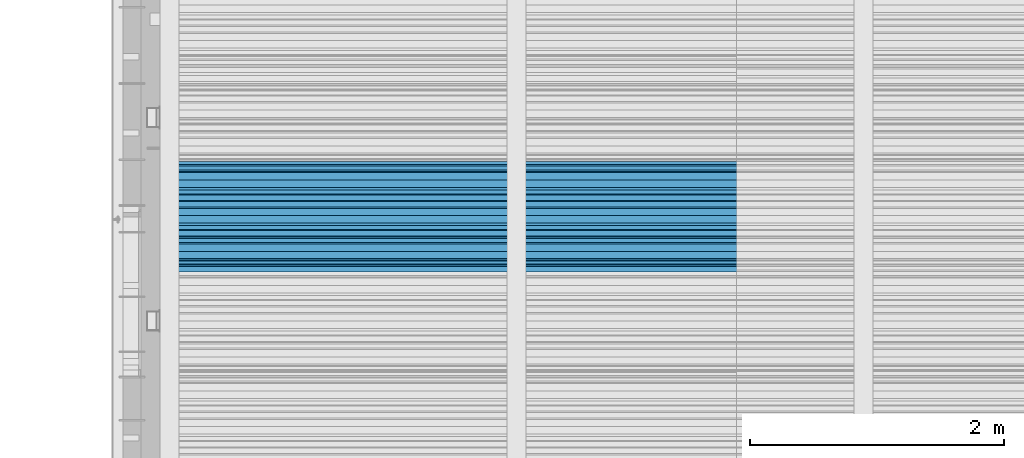
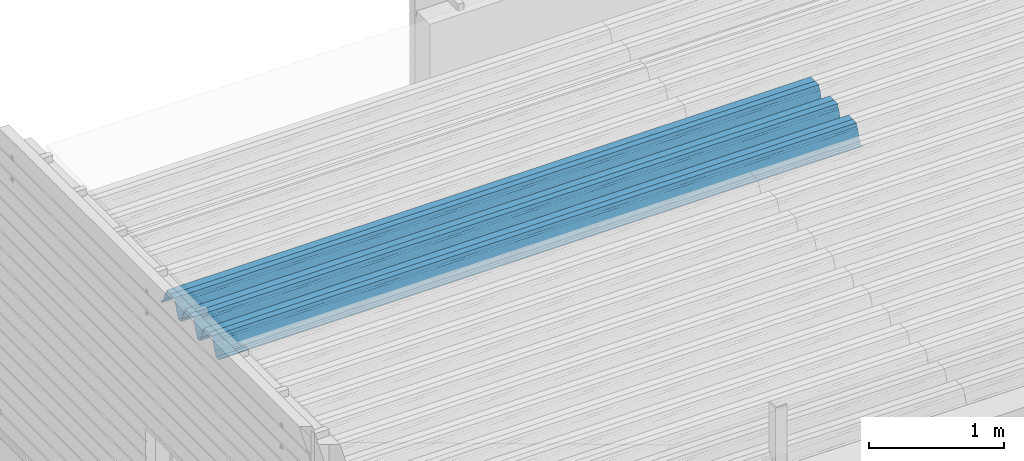
# One storey, part 28 of 153: 1 beam, 1 element without a shape of its own.
"""IFC2X3 building model written with IfcOpenShell, lengths in millimetres."""

from ifc_helpers import new_model, si_unit, frame, origin_with_axes, place, context, subcontext, project, spatial, faceted_brep, material, type_object, element, aggregate, save


model = new_model("IFC2X3")

# Units and contexts
model_context = context("Model", 3, precision=1e-05, world=origin_with_axes())
body_context = subcontext(model_context, "Body", "Model", "MODEL_VIEW")
ifc_project = project(units=[si_unit("LENGTHUNIT", "METRE", prefix="MILLI"), si_unit("AREAUNIT", "SQUARE_METRE"), si_unit("VOLUMEUNIT", "CUBIC_METRE"), si_unit("MASSUNIT", "GRAM", prefix="KILO"), si_unit("TIMEUNIT", "SECOND"), si_unit("PLANEANGLEUNIT", "RADIAN"), si_unit("SOLIDANGLEUNIT", "STERADIAN"), si_unit("THERMODYNAMICTEMPERATUREUNIT", "DEGREE_CELSIUS"), si_unit("LUMINOUSINTENSITYUNIT", "LUMEN")], contexts=[model_context])

# Site, building, storey
site_placement = place(None, origin_with_axes())
site = spatial("IfcSite", under=ifc_project, at=site_placement, CompositionType="ELEMENT")
building_placement = place(site_placement, origin_with_axes())
building = spatial("IfcBuilding", under=site, at=building_placement, CompositionType="ELEMENT")
storey_placement = place(building_placement, origin_with_axes())
storey = spatial("IfcBuildingStorey", under=building, at=storey_placement, Name="8", CompositionType="ELEMENT", Elevation=0.0)

# Assembly, beam
assembly_placement = place(storey_placement, origin_with_axes())
assembly = element("IfcElementAssembly", 1, at=assembly_placement, inside=storey, Name="Steel Assembly", AssemblyPlace="NOTDEFINED", PredefinedType="RIGID_FRAME")
ifc_material = material(Name="STEEL/S355J2")
beam_type = type_object("IfcBeamType", Name="W", PredefinedType="NOTDEFINED")
beam_placement = place(assembly_placement, frame((13534.9999999929, 18704.9497094765, 105791.397257998), z_axis=(0.0, -0.0124990270013869, 0.999921884110963), x_axis=(-1.0, 3.00000001838171e-08, 0.0)))
beam = element("IfcBeam", 2, at=beam_placement, type_object=beam_type, material=ifc_material, ObjectType="W", context=body_context, shape_type="Brep", body=[
    faceted_brep([(0.0, -412.839996337891, -77.0100021362159), (0.0, -409.160003662109, -77.0100021362014), (5530.0, -409.160003662109, -77.0100021362014), (5530.0, -412.839996337891, -77.0100021362159), (0.0, -408.070007324222, -73.4800033569045), (5530.0, -408.070007324222, -73.4800033569045), (0.0, -400.339996337894, -48.0600013732619), (5530.0, -400.339996337894, -48.0600013732619), (0.0, -399.459991455082, -46.5600013732619), (5530.0, -399.459991455082, -46.5600013732619), (0.0, -390.329986572269, -36.5499992370314), (5530.0, -390.329986572269, -36.5499992370314), (0.0, -389.19000244141, -34.6300010680861), (5530.0, -389.19000244141, -34.6300010680861), (0.0, -367.820007324222, 35.3400001526024), (5530.0, -367.820007324222, 35.3400001526024), (0.0, -366.989990234379, 36.8499984741502), (5530.0, -366.989990234379, 36.8499984741502), (0.0, -357.809997558597, 46.8600006103807), (5530.0, -357.809997558597, 46.8600006103807), (0.0, -356.720001220707, 48.7700004577782), (5530.0, -356.720001220707, 48.7700004577782), (0.0, -349.309997558594, 73.1500015258935), (5530.0, -349.309997558594, 73.1500015258935), (0.0, -347.850006103516, 75.2300033569481), (5530.0, -347.850006103516, 75.2300033569481), (0.0, -345.470001220707, 76.010002136245), (5530.0, -345.470001220707, 76.010002136245), (0.0, -305.480010986332, 76.010002136245), (5530.0, -305.480010986332, 76.010002136245), (0.0, -304.279998779301, 75.8000030517578), (5530.0, -304.279998779301, 75.8000030517578), (0.0, -291.679992675785, 71.6999969482567), (5530.0, -291.679992675785, 71.6999969482567), (0.0, -290.179992675789, 71.2300033569481), (5530.0, -290.179992675789, 71.2300033569481), (0.0, -288.720001220707, 71.6999969482567), (5530.0, -288.720001220707, 71.6999969482567), (0.0, -276.119995117191, 75.8000030517869), (5530.0, -276.119995117191, 75.8000030517869), (0.0, -274.929992675785, 76.010002136245), (5530.0, -274.929992675785, 76.010002136245), (0.0, -234.94000244141, 76.010002136245), (5530.0, -234.94000244141, 76.010002136245), (0.0, -232.550003051758, 75.2300033569627), (5530.0, -232.550003051758, 75.2300033569627), (0.0, -231.100006103519, 73.1500015258935), (5530.0, -231.100006103519, 73.1500015258935), (0.0, -223.679992675785, 48.7700004577782), (5530.0, -223.679992675785, 48.7700004577782), (0.0, -222.589996337894, 46.8600006103661), (5530.0, -222.589996337894, 46.8600006103661), (0.0, -213.410003662113, 36.8499984741502), (5530.0, -213.410003662113, 36.8499984741502), (0.0, -212.529998779301, 35.3400001526024), (5530.0, -212.529998779301, 35.3400001526024), (0.0, -191.160003662109, -34.6300010681007), (5530.0, -191.160003662109, -34.6300010681007), (0.0, -190.070007324222, -36.5499992370605), (5530.0, -190.070007324222, -36.5499992370605), (0.0, -180.940002441406, -46.560001373291), (5530.0, -180.940002441406, -46.560001373291), (0.0, -180.059997558597, -48.0600013732619), (5530.0, -180.059997558597, -48.0600013732619), (0.0, -172.330001831055, -73.480003356919), (5530.0, -172.330001831055, -73.480003356919), (0.0, -171.240005493168, -77.0100021362159), (5530.0, -171.240005493168, -77.0100021362159), (0.0, -129.330001831062, -77.0100021362014), (5530.0, -129.330001831062, -77.0100021362014), (0.0, -128.300003051761, -73.480003356919), (5530.0, -128.300003051761, -73.480003356919), (0.0, -120.51999664307, -48.0600013732765), (5530.0, -120.51999664307, -48.0600013732765), (0.0, -119.629997253418, -46.5600013732765), (5530.0, -119.629997253418, -46.5600013732765), (0.0, -110.500000000004, -36.5499992370314), (5530.0, -110.500000000004, -36.5499992370314), (0.0, -109.419998168949, -34.6300010680861), (5530.0, -109.419998168949, -34.6300010680861), (0.0, -88.0500030517615, 35.3400001526024), (5530.0, -88.0500030517615, 35.3400001526024), (0.0, -87.160003662113, 36.8499984741356), (5530.0, -87.160003662113, 36.8499984741356), (0.0, -78.0400009155273, 46.8600006103807), (5530.0, -78.0400009155273, 46.8600006103807), (0.0, -76.8899993896557, 48.7700004577782), (5530.0, -76.8899993896557, 48.7700004577782), (0.0, -69.4800033569336, 73.1500015258935), (5530.0, -69.4800033569336, 73.1500015258935), (0.0, -68.0299987793042, 75.2300033569336), (5530.0, -68.0299987793042, 75.2300033569336), (0.0, -65.6399993896521, 76.010002136245), (5530.0, -65.6399993896521, 76.010002136245), (0.0, -25.6499996185375, 76.0100021362596), (5530.0, -25.6499996185375, 76.0100021362596), (0.0, -24.5100002288891, 75.8000030517724), (5530.0, -24.5100002288891, 75.8000030517724), (0.0, -11.8500003814697, 71.6999969482567), (5530.0, -11.8500003814697, 71.6999969482567), (0.0, -10.3999996185339, 71.2300033569481), (5530.0, -10.3999996185339, 71.2300033569481), (0.0, -8.89999961853391, 71.6999969482567), (5530.0, -8.89999961853391, 71.6999969482567), (0.0, 3.71000003814333, 75.8000030517724), (5530.0, 3.71000003814333, 75.8000030517724), (0.0, 4.90000009536379, 76.0100021362596), (5530.0, 4.90000009536379, 76.0100021362596), (0.0, 44.8899993896484, 76.010002136245), (5530.0, 44.8899993896484, 76.010002136245), (0.0, 47.2799987792932, 75.2300033569481), (5530.0, 47.2799987792932, 75.2300033569481), (0.0, 48.6800003051721, 73.1500015258935), (5530.0, 48.6800003051721, 73.1500015258935), (0.0, 56.1500015258753, 48.7700004577782), (5530.0, 56.1500015258753, 48.7700004577782), (0.0, 57.2400016784632, 46.8600006103807), (5530.0, 57.2400016784632, 46.8600006103807), (0.0, 66.3700027465784, 36.8499984741211), (5530.0, 66.3700027465784, 36.8499984741211), (0.0, 67.2499999999964, 35.3400001526024), (5530.0, 67.2499999999964, 35.3400001526024), (0.0, 88.6200027465748, -34.6300010681007), (5530.0, 88.6200027465748, -34.6300010681007), (0.0, 89.709999084469, -36.549999237046), (5530.0, 89.709999084469, -36.549999237046), (0.0, 98.8899993896412, -46.5600013732765), (5530.0, 98.8899993896412, -46.5600013732765), (0.0, 99.7699966430628, -48.0600013732765), (5530.0, 99.7699966430628, -48.0600013732765), (0.0, 107.499999999996, -73.4800033569336), (5530.0, 107.499999999996, -73.4800033569336), (0.0, 108.589996337887, -77.0100021362014), (5530.0, 108.589996337887, -77.0100021362014), (0.0, 112.269996643063, -77.0100021362159), (5530.0, 112.269996643063, -77.0100021362159), (0.0, 146.759994506836, -77.0100021362159), (5530.0, 146.759994506836, -77.0100021362159), (0.0, 150.440002441403, -77.0100021362159), (5530.0, 150.440002441403, -77.0100021362159), (0.0, 151.529998779297, -73.480003356919), (5530.0, 151.529998779297, -73.480003356919), (0.0, 159.30999755859, -48.0600013732765), (5530.0, 159.30999755859, -48.0600013732765), (0.0, 160.190002441406, -46.5600013732619), (5530.0, 160.190002441406, -46.5600013732619), (0.0, 169.320007324215, -36.549999237046), (5530.0, 169.320007324215, -36.549999237046), (0.0, 170.410003662106, -34.6300010680861), (5530.0, 170.410003662106, -34.6300010680861), (0.0, 191.779998779293, 35.3400001526024), (5530.0, 191.779998779293, 35.3400001526024), (0.0, 192.660003662109, 36.8499984741502), (5530.0, 192.660003662109, 36.8499984741502), (0.0, 201.789993286129, 46.8600006103661), (5530.0, 201.789993286129, 46.8600006103661), (0.0, 202.880004882809, 48.7700004577637), (5530.0, 202.880004882809, 48.7700004577637), (0.0, 210.350006103512, 73.150001525908), (5530.0, 210.350006103512, 73.150001525908), (0.0, 211.800003051754, 75.2300033569481), (5530.0, 211.800003051754, 75.2300033569481), (0.0, 214.190002441406, 76.010002136245), (5530.0, 214.190002441406, 76.010002136245), (0.0, 254.179992675778, 76.010002136245), (5530.0, 254.179992675778, 76.010002136245), (0.0, 255.320007324215, 75.8000030517869), (5530.0, 255.320007324215, 75.8000030517869), (0.0, 267.980010986324, 71.6999969482713), (5530.0, 267.980010986324, 71.6999969482713), (0.0, 269.429992675778, 71.2300033569481), (5530.0, 269.429992675778, 71.2300033569481), (0.0, 270.880004882809, 71.6999969482567), (5530.0, 270.880004882809, 71.6999969482567), (0.0, 283.540008544918, 75.8000030517869), (5530.0, 283.540008544918, 75.8000030517869), (0.0, 284.679992675778, 76.010002136245), (5530.0, 284.679992675778, 76.010002136245), (0.0, 324.670013427731, 76.010002136245), (5530.0, 324.670013427731, 76.010002136245), (0.0, 327.049987792969, 75.2300033569627), (5530.0, 327.049987792969, 75.2300033569627), (0.0, 328.510009765625, 73.1500015258789), (5530.0, 328.510009765625, 73.1500015258789), (0.0, 335.980010986324, 48.7700004577782), (5530.0, 335.980010986324, 48.7700004577782), (0.0, 337.05999755859, 46.8600006103661), (5530.0, 337.05999755859, 46.8600006103661), (0.0, 346.190002441399, 36.8499984741356), (5530.0, 346.190002441399, 36.8499984741356), (0.0, 347.079986572266, 35.3400001526024), (5530.0, 347.079986572266, 35.3400001526024), (0.0, 368.450012207028, -34.6300010680861), (5530.0, 368.450012207028, -34.6300010680861), (0.0, 369.529998779293, -36.5499992370314), (5530.0, 369.529998779293, -36.5499992370314), (0.0, 378.660003662106, -46.5600013732619), (5530.0, 378.660003662106, -46.5600013732619), (0.0, 379.540008544918, -48.0600013732619), (5530.0, 379.540008544918, -48.0600013732619), (0.0, 387.329986572262, -73.480003356919), (5530.0, 387.329986572262, -73.480003356919), (0.0, 388.410003662109, -77.0100021362159), (5530.0, 388.410003662109, -77.0100021362159), (0.0, 392.100006103512, -77.0100021362159), (5530.0, 392.100006103512, -77.0100021362159), (0.0, 426.589996337887, -77.0100021362159), (5530.0, 426.589996337887, -77.0100021362159), (0.0, 430.269989013668, -77.0100021362159), (5530.0, 430.269989013668, -77.0100021362159), (0.0, 431.359985351559, -73.4800033569045), (5530.0, 431.359985351559, -73.4800033569045), (0.0, 433.179992675778, -67.5699996948097), (5530.0, 433.179992675778, -67.5699996948097), (0.0, 432.220001220699, -67.2699966430373), (5530.0, 432.220001220699, -67.2699966430373), (0.0, 430.410003662106, -73.1800003051612), (5530.0, 430.410003662106, -73.1800003051612), (0.0, 429.529998779293, -76.0100021362159), (5530.0, 429.529998779293, -76.0100021362159), (0.0, 426.589996337891, -76.0100021362159), (5530.0, 426.589996337891, -76.0100021362159), (0.0, 392.100006103512, -76.0100021362159), (5530.0, 392.100006103512, -76.0100021362159), (0.0, 389.149993896481, -76.0100021362014), (5530.0, 389.149993896481, -76.0100021362014), (0.0, 388.279998779293, -73.1800003051467), (5530.0, 388.279998779293, -73.1800003051467), (0.0, 380.470001220699, -47.659999847383), (5530.0, 380.470001220699, -47.659999847383), (0.0, 379.470001220699, -45.9599990844436), (5530.0, 379.470001220699, -45.9599990844436), (0.0, 370.350006103512, -35.9599990844581), (5530.0, 370.350006103512, -35.9599990844581), (0.0, 369.369995117184, -34.2299995422218), (5530.0, 369.369995117184, -34.2299995422218), (0.0, 347.999999999996, 35.7500000000146), (5530.0, 347.999999999996, 35.7500000000146), (0.0, 346.999999999996, 37.4399986267235), (5530.0, 346.999999999996, 37.4399986267235), (0.0, 337.880004882809, 47.450000762954), (5530.0, 337.880004882809, 47.450000762954), (0.0, 336.899993896481, 49.1699981689453), (5530.0, 336.899993896481, 49.1699981689453), (0.0, 329.420013427731, 73.5999984741356), (5530.0, 329.420013427731, 73.5999984741356), (0.0, 327.679992675781, 76.0699996948533), (5530.0, 327.679992675781, 76.0699996948533), (0.0, 324.829986572262, 77.010002136245), (5530.0, 324.829986572262, 77.010002136245), (0.0, 284.589996337887, 77.010002136245), (5530.0, 284.589996337887, 77.010002136245), (0.0, 283.290008544922, 76.769996643081), (5530.0, 283.290008544922, 76.769996643081), (0.0, 270.570007324215, 72.6500015258935), (5530.0, 270.570007324215, 72.6500015258935), (0.0, 269.429992675781, 72.2799987793114), (5530.0, 269.429992675781, 72.2799987793114), (0.0, 268.279998779293, 72.650001525908), (5530.0, 268.279998779293, 72.650001525908), (0.0, 255.570007324219, 76.769996643081), (5530.0, 255.570007324219, 76.769996643081), (0.0, 254.270004272461, 77.0100021362596), (5530.0, 254.270004272461, 77.0100021362596), (0.0, 214.029998779293, 77.0100021362596), (5530.0, 214.029998779293, 77.0100021362596), (0.0, 211.179992675781, 76.0699996948388), (5530.0, 211.179992675781, 76.0699996948388), (0.0, 209.440002441403, 73.5999984741356), (5530.0, 209.440002441403, 73.5999984741356), (0.0, 201.960006713864, 49.1699981689599), (5530.0, 201.960006713864, 49.1699981689599), (0.0, 200.979995727532, 47.450000762954), (5530.0, 200.979995727532, 47.450000762954), (0.0, 191.850006103508, 37.4399986267235), (5530.0, 191.850006103508, 37.4399986267235), (0.0, 190.860000610352, 35.7500000000146), (5530.0, 190.860000610352, 35.7500000000146), (0.0, 169.49000549316, -34.2299995422218), (5530.0, 169.49000549316, -34.2299995422218), (0.0, 168.509994506832, -35.9599990844581), (5530.0, 168.509994506832, -35.9599990844581), (0.0, 159.380004882805, -45.9599990844436), (5530.0, 159.380004882805, -45.9599990844436), (0.0, 158.389999389645, -47.6599998473976), (5530.0, 158.389999389645, -47.6599998473976), (0.0, 150.580001831051, -73.1800003051612), (5530.0, 150.580001831051, -73.1800003051612), (0.0, 149.710006713864, -76.0100021362159), (5530.0, 149.710006713864, -76.0100021362159), (0.0, 146.759994506836, -76.0100021362159), (5530.0, 146.759994506836, -76.0100021362159), (0.0, 112.269996643063, -76.0100021362159), (5530.0, 112.269996643063, -76.0100021362159), (0.0, 109.319999694821, -76.0100021362159), (5530.0, 109.319999694821, -76.0100021362159), (0.0, 108.449996948239, -73.1900024413917), (5530.0, 108.449996948239, -73.1900024413917), (0.0, 100.690002441406, -47.659999847383), (5530.0, 100.690002441406, -47.659999847383), (0.0, 99.6999969482386, -45.9599990844581), (5530.0, 99.6999969482386, -45.9599990844581), (0.0, 90.5199966430664, -35.9599990844581), (5530.0, 90.5199966430664, -35.9599990844581), (0.0, 89.5400009155273, -34.2299995422218), (5530.0, 89.5400009155273, -34.2299995422218), (0.0, 68.1699981689417, 35.7500000000146), (5530.0, 68.1699981689417, 35.7500000000146), (0.0, 67.1699981689417, 37.4399986267235), (5530.0, 67.1699981689417, 37.4399986267235), (0.0, 58.0499992370569, 47.4500007629686), (5530.0, 58.0499992370569, 47.4500007629686), (0.0, 57.0699996948206, 49.1699981689599), (5530.0, 57.0699996948206, 49.1699981689599), (0.0, 49.5900001525843, 73.5899963379052), (5530.0, 49.5900001525843, 73.5899963379052), (0.0, 47.9099998474085, 76.0699996948388), (5530.0, 47.9099998474085, 76.0699996948388), (0.0, 45.0499992370569, 77.010002136245), (5530.0, 45.0499992370569, 77.010002136245), (0.0, 4.82000017165774, 77.010002136245), (5530.0, 4.82000017165774, 77.010002136245), (0.0, 3.47000002860659, 76.7699966430955), (5530.0, 3.47000002860659, 76.7699966430955), (0.0, -9.19999980926514, 72.6500015258935), (5530.0, -9.19999980926514, 72.6500015258935), (0.0, -10.3900003433264, 72.2799987792969), (5530.0, -10.3900003433264, 72.2799987792969), (0.0, -11.5399999618567, 72.6500015258935), (5530.0, -11.5399999618567, 72.6500015258935), (0.0, -24.2600002288855, 76.769996643081), (5530.0, -24.2600002288855, 76.769996643081), (0.0, -25.559999465946, 77.0100021362596), (5530.0, -25.559999465946, 77.0100021362596), (0.0, -65.8000030517615, 77.0100021362596), (5530.0, -65.8000030517615, 77.0100021362596), (0.0, -68.6500015258862, 76.0699996948533), (5530.0, -68.6500015258862, 76.0699996948533), (0.0, -70.3899993896521, 73.5999984741356), (5530.0, -70.3899993896521, 73.5999984741356), (0.0, -77.8199996948242, 49.1800003051903), (5530.0, -77.8199996948242, 49.1800003051903), (0.0, -78.8399963378943, 47.450000762954), (5530.0, -78.8399963378943, 47.450000762954), (0.0, -87.9700012207031, 37.4399986267235), (5530.0, -87.9700012207031, 37.4399986267235), (0.0, -88.9700012207068, 35.7500000000146), (5530.0, -88.9700012207068, 35.7500000000146), (0.0, -110.339996337894, -34.2299995422218), (5530.0, -110.339996337894, -34.2299995422218), (0.0, -111.319999694828, -35.9599990844581), (5530.0, -111.319999694828, -35.9599990844581), (0.0, -120.440002441406, -45.9599990844436), (5530.0, -120.440002441406, -45.9599990844436), (0.0, -121.44000244141, -47.6599998473976), (5530.0, -121.44000244141, -47.6599998473976), (0.0, -129.250000000004, -73.1900024413771), (5530.0, -129.250000000004, -73.1900024413771), (0.0, -130.080001831062, -76.0100021362159), (5530.0, -130.080001831062, -76.0100021362159), (0.0, -170.5, -76.0100021362014), (5530.0, -170.5, -76.0100021362014), (0.0, -171.380004882816, -73.1900024413917), (5530.0, -171.380004882816, -73.1900024413917), (0.0, -179.139999389652, -47.6599998473976), (5530.0, -179.139999389652, -47.6599998473976), (0.0, -180.130004882816, -45.9599990844581), (5530.0, -180.130004882816, -45.9599990844581), (0.0, -189.259994506836, -35.9599990844581), (5530.0, -189.259994506836, -35.9599990844581), (0.0, -190.240005493168, -34.2299995422218), (5530.0, -190.240005493168, -34.2299995422218), (0.0, -211.610000610355, 35.7500000000146), (5530.0, -211.610000610355, 35.7500000000146), (0.0, -212.600006103519, 37.4399986267381), (5530.0, -212.600006103519, 37.4399986267381), (0.0, -221.779998779301, 47.450000762954), (5530.0, -221.779998779301, 47.450000762954), (0.0, -222.75999450684, 49.1699981689599), (5530.0, -222.75999450684, 49.1699981689599), (0.0, -230.190002441406, 73.5999984741356), (5530.0, -230.190002441406, 73.5999984741356), (0.0, -231.919998168945, 76.0699996948388), (5530.0, -231.919998168945, 76.0699996948388), (0.0, -234.779998779301, 77.010002136245), (5530.0, -234.779998779301, 77.010002136245), (0.0, -275.010009765629, 77.010002136245), (5530.0, -275.010009765629, 77.010002136245), (0.0, -276.359985351563, 76.769996643081), (5530.0, -276.359985351563, 76.769996643081), (0.0, -289.029998779297, 72.6500015258789), (5530.0, -289.029998779297, 72.6500015258789), (0.0, -290.179992675785, 72.2799987793114), (5530.0, -290.179992675785, 72.2799987793114), (0.0, -291.380004882816, 72.650001525908), (5530.0, -291.380004882816, 72.650001525908), (0.0, -304.040008544926, 76.769996643081), (5530.0, -304.040008544926, 76.769996643081), (0.0, -305.390014648441, 77.010002136245), (5530.0, -305.390014648441, 77.010002136245), (0.0, -345.63000488282, 77.0100021362596), (5530.0, -345.63000488282, 77.0100021362596), (0.0, -348.480010986332, 76.0699996948388), (5530.0, -348.480010986332, 76.0699996948388), (0.0, -350.220001220707, 73.5999984741356), (5530.0, -350.220001220707, 73.5999984741356), (0.0, -357.649993896492, 49.1699981689599), (5530.0, -357.649993896492, 49.1699981689599), (0.0, -358.63000488282, 47.450000762954), (5530.0, -358.63000488282, 47.450000762954), (0.0, -367.809997558594, 37.4300003051903), (5530.0, -367.809997558594, 37.4300003051903), (0.0, -368.750000000004, 35.7299995422654), (5530.0, -368.750000000004, 35.7299995422654), (0.0, -390.109985351566, -34.2200012207031), (5530.0, -390.109985351566, -34.2200012207031), (0.0, -391.140014648441, -35.9500007629249), (5530.0, -391.140014648441, -35.9500007629249), (0.0, -400.269989013676, -45.9599990844436), (5530.0, -400.269989013676, -45.9599990844436), (0.0, -401.269989013672, -47.6599998473976), (5530.0, -401.269989013672, -47.6599998473976), (0.0, -409.029998779297, -73.1900024413917), (5530.0, -409.029998779297, -73.1900024413917), (0.0, -409.899993896488, -76.0100021362159), (5530.0, -409.899993896488, -76.0100021362159), (0.0, -412.839996337891, -76.0100021362159), (5530.0, -412.839996337891, -76.0100021362159), (0.0, -433.179992675785, -76.0100021362159), (5530.0, -433.179992675785, -76.0100021362159), (0.0, -433.179992675785, -77.0100021362159), (5530.0, -433.179992675785, -77.0100021362159)], [[[0, 1, 2, 3]], [[1, 4, 5, 2]], [[4, 6, 7, 5]], [[6, 8, 9, 7]], [[8, 10, 11, 9]], [[10, 12, 13, 11]], [[12, 14, 15, 13]], [[14, 16, 17, 15]], [[16, 18, 19, 17]], [[18, 20, 21, 19]], [[20, 22, 23, 21]], [[22, 24, 25, 23]], [[24, 26, 27, 25]], [[26, 28, 29, 27]], [[28, 30, 31, 29]], [[30, 32, 33, 31]], [[32, 34, 35, 33]], [[34, 36, 37, 35]], [[36, 38, 39, 37]], [[38, 40, 41, 39]], [[40, 42, 43, 41]], [[42, 44, 45, 43]], [[44, 46, 47, 45]], [[46, 48, 49, 47]], [[48, 50, 51, 49]], [[50, 52, 53, 51]], [[52, 54, 55, 53]], [[54, 56, 57, 55]], [[56, 58, 59, 57]], [[58, 60, 61, 59]], [[60, 62, 63, 61]], [[62, 64, 65, 63]], [[64, 66, 67, 65]], [[66, 68, 69, 67]], [[68, 70, 71, 69]], [[70, 72, 73, 71]], [[72, 74, 75, 73]], [[74, 76, 77, 75]], [[76, 78, 79, 77]], [[78, 80, 81, 79]], [[80, 82, 83, 81]], [[82, 84, 85, 83]], [[84, 86, 87, 85]], [[86, 88, 89, 87]], [[88, 90, 91, 89]], [[90, 92, 93, 91]], [[92, 94, 95, 93]], [[94, 96, 97, 95]], [[96, 98, 99, 97]], [[98, 100, 101, 99]], [[100, 102, 103, 101]], [[102, 104, 105, 103]], [[104, 106, 107, 105]], [[106, 108, 109, 107]], [[108, 110, 111, 109]], [[110, 112, 113, 111]], [[112, 114, 115, 113]], [[114, 116, 117, 115]], [[116, 118, 119, 117]], [[118, 120, 121, 119]], [[120, 122, 123, 121]], [[122, 124, 125, 123]], [[124, 126, 127, 125]], [[126, 128, 129, 127]], [[128, 130, 131, 129]], [[130, 132, 133, 131]], [[132, 134, 135, 133]], [[134, 136, 137, 135]], [[136, 138, 139, 137]], [[138, 140, 141, 139]], [[140, 142, 143, 141]], [[142, 144, 145, 143]], [[144, 146, 147, 145]], [[146, 148, 149, 147]], [[148, 150, 151, 149]], [[150, 152, 153, 151]], [[152, 154, 155, 153]], [[154, 156, 157, 155]], [[156, 158, 159, 157]], [[158, 160, 161, 159]], [[160, 162, 163, 161]], [[162, 164, 165, 163]], [[164, 166, 167, 165]], [[166, 168, 169, 167]], [[168, 170, 171, 169]], [[170, 172, 173, 171]], [[172, 174, 175, 173]], [[174, 176, 177, 175]], [[176, 178, 179, 177]], [[178, 180, 181, 179]], [[180, 182, 183, 181]], [[182, 184, 185, 183]], [[184, 186, 187, 185]], [[186, 188, 189, 187]], [[188, 190, 191, 189]], [[190, 192, 193, 191]], [[192, 194, 195, 193]], [[194, 196, 197, 195]], [[196, 198, 199, 197]], [[198, 200, 201, 199]], [[200, 202, 203, 201]], [[202, 204, 205, 203]], [[204, 206, 207, 205]], [[206, 208, 209, 207]], [[208, 210, 211, 209]], [[210, 212, 213, 211]], [[212, 214, 215, 213]], [[214, 216, 217, 215]], [[216, 218, 219, 217]], [[218, 220, 221, 219]], [[220, 222, 223, 221]], [[222, 224, 225, 223]], [[224, 226, 227, 225]], [[226, 228, 229, 227]], [[228, 230, 231, 229]], [[230, 232, 233, 231]], [[232, 234, 235, 233]], [[234, 236, 237, 235]], [[236, 238, 239, 237]], [[238, 240, 241, 239]], [[240, 242, 243, 241]], [[242, 244, 245, 243]], [[244, 246, 247, 245]], [[246, 248, 249, 247]], [[248, 250, 251, 249]], [[250, 252, 253, 251]], [[252, 254, 255, 253]], [[254, 256, 257, 255]], [[256, 258, 259, 257]], [[258, 260, 261, 259]], [[260, 262, 263, 261]], [[262, 264, 265, 263]], [[264, 266, 267, 265]], [[266, 268, 269, 267]], [[268, 270, 271, 269]], [[270, 272, 273, 271]], [[272, 274, 275, 273]], [[274, 276, 277, 275]], [[276, 278, 279, 277]], [[278, 280, 281, 279]], [[280, 282, 283, 281]], [[282, 284, 285, 283]], [[284, 286, 287, 285]], [[286, 288, 289, 287]], [[288, 290, 291, 289]], [[290, 292, 293, 291]], [[292, 294, 295, 293]], [[294, 296, 297, 295]], [[296, 298, 299, 297]], [[298, 300, 301, 299]], [[300, 302, 303, 301]], [[302, 304, 305, 303]], [[304, 306, 307, 305]], [[306, 308, 309, 307]], [[308, 310, 311, 309]], [[310, 312, 313, 311]], [[312, 314, 315, 313]], [[314, 316, 317, 315]], [[316, 318, 319, 317]], [[318, 320, 321, 319]], [[320, 322, 323, 321]], [[322, 324, 325, 323]], [[324, 326, 327, 325]], [[326, 328, 329, 327]], [[328, 330, 331, 329]], [[330, 332, 333, 331]], [[332, 334, 335, 333]], [[334, 336, 337, 335]], [[336, 338, 339, 337]], [[338, 340, 341, 339]], [[340, 342, 343, 341]], [[342, 344, 345, 343]], [[344, 346, 347, 345]], [[346, 348, 349, 347]], [[348, 350, 351, 349]], [[350, 352, 353, 351]], [[352, 354, 355, 353]], [[354, 356, 357, 355]], [[356, 358, 359, 357]], [[358, 360, 361, 359]], [[360, 362, 363, 361]], [[362, 364, 365, 363]], [[364, 366, 367, 365]], [[366, 368, 369, 367]], [[368, 370, 371, 369]], [[370, 372, 373, 371]], [[372, 374, 375, 373]], [[374, 376, 377, 375]], [[376, 378, 379, 377]], [[378, 380, 381, 379]], [[380, 382, 383, 381]], [[382, 384, 385, 383]], [[384, 386, 387, 385]], [[386, 388, 389, 387]], [[388, 390, 391, 389]], [[390, 392, 393, 391]], [[392, 394, 395, 393]], [[394, 396, 397, 395]], [[396, 398, 399, 397]], [[398, 400, 401, 399]], [[400, 402, 403, 401]], [[402, 404, 405, 403]], [[404, 406, 407, 405]], [[406, 408, 409, 407]], [[408, 410, 411, 409]], [[410, 412, 413, 411]], [[412, 414, 415, 413]], [[414, 416, 417, 415]], [[416, 418, 419, 417]], [[418, 420, 421, 419]], [[420, 422, 423, 421]], [[422, 424, 425, 423]], [[424, 426, 427, 425]], [[426, 428, 429, 427]], [[428, 430, 431, 429]], [[430, 0, 3, 431]], [[5, 7, 9, 11, 13, 15, 17, 19, 21, 23, 25, 27, 29, 31, 33, 35, 37, 39, 41, 43, 45, 47, 49, 51, 53, 55, 57, 59, 61, 63, 65, 67, 69, 71, 73, 75, 77, 79, 81, 83, 85, 87, 89, 91, 93, 95, 97, 99, 101, 103, 105, 107, 109, 111, 113, 115, 117, 119, 121, 123, 125, 127, 129, 131, 133, 135, 137, 139, 141, 143, 145, 147, 149, 151, 153, 155, 157, 159, 161, 163, 165, 167, 169, 171, 173, 175, 177, 179, 181, 183, 185, 187, 189, 191, 193, 195, 197, 199, 201, 203, 205, 207, 209, 211, 213, 215, 217, 219, 221, 223, 225, 227, 229, 231, 233, 235, 237, 239, 241, 243, 245, 247, 249, 251, 253, 255, 257, 259, 261, 263, 265, 267, 269, 271, 273, 275, 277, 279, 281, 283, 285, 287, 289, 291, 293, 295, 297, 299, 301, 303, 305, 307, 309, 311, 313, 315, 317, 319, 321, 323, 325, 327, 329, 331, 333, 335, 337, 339, 341, 343, 345, 347, 349, 351, 353, 355, 357, 359, 361, 363, 365, 367, 369, 371, 373, 375, 377, 379, 381, 383, 385, 387, 389, 391, 393, 395, 397, 399, 401, 403, 405, 407, 409, 411, 413, 415, 417, 419, 421, 423, 425, 427, 429, 431, 3, 2]], [[430, 428, 426, 424, 422, 420, 418, 416, 414, 412, 410, 408, 406, 404, 402, 400, 398, 396, 394, 392, 390, 388, 386, 384, 382, 380, 378, 376, 374, 372, 370, 368, 366, 364, 362, 360, 358, 356, 354, 352, 350, 348, 346, 344, 342, 340, 338, 336, 334, 332, 330, 328, 326, 324, 322, 320, 318, 316, 314, 312, 310, 308, 306, 304, 302, 300, 298, 296, 294, 292, 290, 288, 286, 284, 282, 280, 278, 276, 274, 272, 270, 268, 266, 264, 262, 260, 258, 256, 254, 252, 250, 248, 246, 244, 242, 240, 238, 236, 234, 232, 230, 228, 226, 224, 222, 220, 218, 216, 214, 212, 210, 208, 206, 204, 202, 200, 198, 196, 194, 192, 190, 188, 186, 184, 182, 180, 178, 176, 174, 172, 170, 168, 166, 164, 162, 160, 158, 156, 154, 152, 150, 148, 146, 144, 142, 140, 138, 136, 134, 132, 130, 128, 126, 124, 122, 120, 118, 116, 114, 112, 110, 108, 106, 104, 102, 100, 98, 96, 94, 92, 90, 88, 86, 84, 82, 80, 78, 76, 74, 72, 70, 68, 66, 64, 62, 60, 58, 56, 54, 52, 50, 48, 46, 44, 42, 40, 38, 36, 34, 32, 30, 28, 26, 24, 22, 20, 18, 16, 14, 12, 10, 8, 6, 4, 1, 0]]]),
])
aggregate(assembly, [beam])

save(model, "model.ifc")
